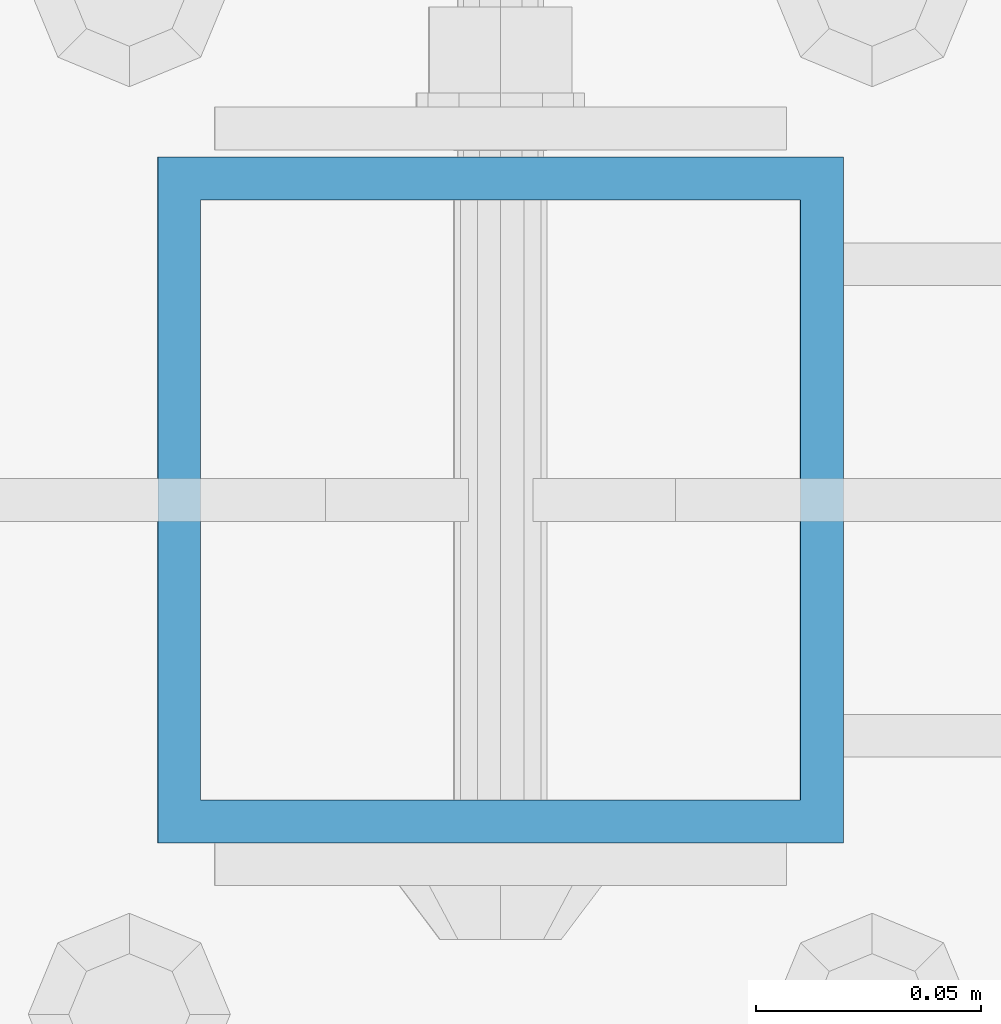
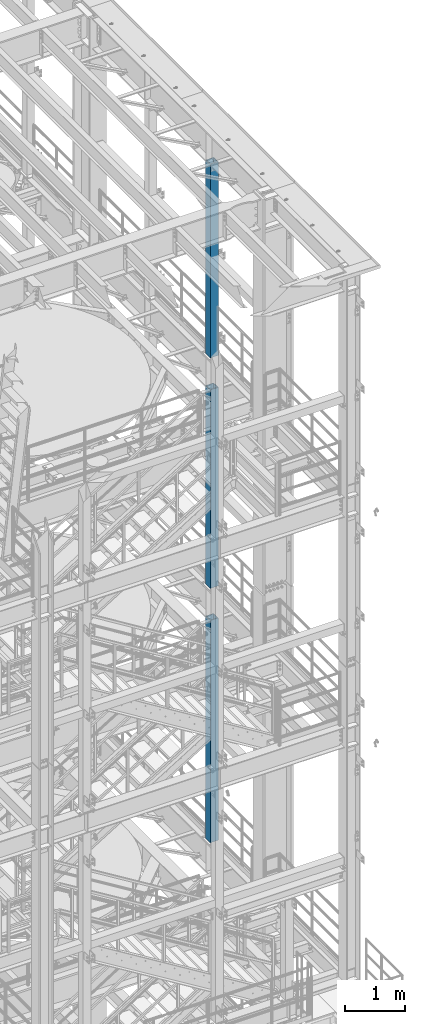
# One storey, part 674 of 1876: 3 columns, 3 elements without a shape of their own.
"""IFC2X3 building model written with IfcOpenShell, lengths in millimetres."""

from ifc_helpers import new_model, si_unit, frame, origin_with_axes, place, context, subcontext, project, spatial, faceted_brep, material, type_object, element, aggregate, save


model = new_model("IFC2X3")

# Units and contexts
model_context = context("Model", 3, precision=1e-05, world=origin_with_axes())
body_context = subcontext(model_context, "Body", "Model", "MODEL_VIEW")
ifc_project = project(units=[si_unit("LENGTHUNIT", "METRE", prefix="MILLI"), si_unit("AREAUNIT", "SQUARE_METRE"), si_unit("VOLUMEUNIT", "CUBIC_METRE"), si_unit("MASSUNIT", "GRAM", prefix="KILO"), si_unit("TIMEUNIT", "SECOND"), si_unit("PLANEANGLEUNIT", "RADIAN"), si_unit("SOLIDANGLEUNIT", "STERADIAN"), si_unit("THERMODYNAMICTEMPERATUREUNIT", "DEGREE_CELSIUS"), si_unit("LUMINOUSINTENSITYUNIT", "LUMEN")], contexts=[model_context])

# Site, building, storey
site_placement = place(None, origin_with_axes())
site = spatial("IfcSite", under=ifc_project, at=site_placement, CompositionType="ELEMENT")
building_placement = place(site_placement, origin_with_axes())
building = spatial("IfcBuilding", under=site, at=building_placement, Name="Undefined", CompositionType="ELEMENT")
storey_placement = place(building_placement, origin_with_axes())
storey = spatial("IfcBuildingStorey", under=building, at=storey_placement, Name="Undefined", CompositionType="ELEMENT", Elevation=0.0)

# Assembly, column
assembly_1_placement = place(storey_placement, origin_with_axes())
assembly_1 = element("IfcElementAssembly", 1, at=assembly_1_placement, inside=storey, Name="BEAM", AssemblyPlace="NOTDEFINED", PredefinedType="RIGID_FRAME")
ifc_material = material()
column_type = type_object("IfcColumnType", Name="HSS6X6X3/8", PredefinedType="NOTDEFINED")
column_1_placement = place(assembly_1_placement, frame((7620.0, -2540.0, 17983.2), z_axis=(-1.0, 0.0, 0.0), x_axis=(0.0, 0.0, 1.0)))
column_1 = element("IfcColumn", 2, at=column_1_placement, type_object=column_type, material=ifc_material, Name="COLUMN", ObjectType="HSS6X6X3/8", context=body_context, shape_type="Brep", body=[
    faceted_brep([(12.7000000000016, 66.6750000000002, -66.6750000000002), (12.7000000000016, -66.6750000000002, -66.6750000000002), (3937.0, -66.6750000000002, -66.675), (3937.0, 66.6750000000002, -66.675), (12.7000000000016, -66.6750000000002, 66.6750000000002), (3937.0, -66.6750000000002, 66.675), (12.7000000000016, 66.6750000000002, 66.6750000000002), (3937.0, 66.6750000000002, 66.675), (12.7000000000016, 76.1999999999998, -76.1999999999998), (12.7000000000016, 76.1999999999998, 76.1999999999998), (3937.0, 76.1999999999998, 76.2), (3937.0, 76.1999999999998, -76.2), (12.7000000000016, -76.1999999999998, 76.1999999999998), (3937.0, -76.1999999999998, 76.2), (12.7000000000016, -76.1999999999998, -76.1999999999998), (3937.0, -76.1999999999998, -76.2)], [[[0, 1, 2, 3]], [[1, 4, 5, 2]], [[4, 6, 7, 5]], [[6, 0, 3, 7]], [[8, 9, 10, 11]], [[9, 12, 13, 10]], [[12, 14, 15, 13]], [[14, 8, 11, 15]], [[13, 15, 11, 10], [5, 7, 3, 2]], [[14, 12, 9, 8], [6, 4, 1, 0]]]),
])
aggregate(assembly_1, [column_1])

assembly_2_placement = place(storey_placement, origin_with_axes())
assembly_2 = element("IfcElementAssembly", 3, at=assembly_2_placement, inside=storey, Name="BEAM", AssemblyPlace="NOTDEFINED", PredefinedType="RIGID_FRAME")
column_2_placement = place(assembly_2_placement, frame((7620.0, -2540.0, 13309.6), z_axis=(-1.0, 0.0, 0.0), x_axis=(0.0, 0.0, 1.0)))
column_2 = element("IfcColumn", 4, at=column_2_placement, type_object=column_type, material=ifc_material, Name="COLUMN", ObjectType="HSS6X6X3/8", context=body_context, shape_type="Brep", body=[
    faceted_brep([(12.7000000000016, 66.6750000000002, -66.6750000000002), (12.7000000000016, -66.6750000000002, -66.6750000000002), (4038.6, -66.6750000000002, -66.675), (4038.6, 66.6750000000002, -66.675), (12.7000000000016, -66.6750000000002, 66.6750000000002), (4038.6, -66.6750000000002, 66.675), (12.7000000000016, 66.6750000000002, 66.6750000000002), (4038.6, 66.6750000000002, 66.675), (12.7000000000016, 76.1999999999998, -76.1999999999998), (12.7000000000016, 76.1999999999998, 76.1999999999998), (4038.6, 76.1999999999998, 76.2), (4038.6, 76.1999999999998, -76.2), (12.7000000000016, -76.1999999999998, 76.1999999999998), (4038.6, -76.1999999999998, 76.2), (12.7000000000016, -76.1999999999998, -76.1999999999998), (4038.6, -76.1999999999998, -76.2)], [[[0, 1, 2, 3]], [[1, 4, 5, 2]], [[4, 6, 7, 5]], [[6, 0, 3, 7]], [[8, 9, 10, 11]], [[9, 12, 13, 10]], [[12, 14, 15, 13]], [[14, 8, 11, 15]], [[13, 15, 11, 10], [5, 7, 3, 2]], [[14, 12, 9, 8], [6, 4, 1, 0]]]),
])
aggregate(assembly_2, [column_2])

assembly_3_placement = place(storey_placement, origin_with_axes())
assembly_3 = element("IfcElementAssembly", 5, at=assembly_3_placement, inside=storey, Name="BEAM", AssemblyPlace="NOTDEFINED", PredefinedType="RIGID_FRAME")
column_3_placement = place(assembly_3_placement, frame((7620.0, -2540.0, 8153.4), z_axis=(-0.999999999563517, 0.0, -2.95459999870218e-05), x_axis=(-2.95459999861759e-05, 0.0, 0.999999999563517)))
column_3 = element("IfcColumn", 6, at=column_3_placement, type_object=column_type, material=ifc_material, Name="COLUMN", ObjectType="HSS6X6X3/8", context=body_context, shape_type="Brep", body=[
    faceted_brep([(12.698030025992, 66.6750000000002, -66.675), (12.698030025992, -66.6750000000002, -66.675), (4521.2007045434, -66.6750000000002, -66.675), (4521.2007045434, 66.6750000000002, -66.675), (12.7019699850925, -66.6750000000002, 66.675), (4521.20070454334, -66.6750000000002, 66.675), (12.7019699850925, 66.6750000000002, 66.675), (4521.20070454334, 66.6750000000002, 66.675), (12.6977486003425, 76.1999999999998, -76.2), (12.7022514107421, 76.1999999999998, 76.2), (4521.20070454334, 76.1999999999998, 76.2), (4521.2007045434, 76.1999999999998, -76.2), (12.7022514107421, -76.1999999999998, 76.2), (4521.20070454334, -76.1999999999998, 76.2), (12.6977486003425, -76.1999999999998, -76.2), (4521.2007045434, -76.1999999999998, -76.2)], [[[0, 1, 2, 3]], [[1, 4, 5, 2]], [[4, 6, 7, 5]], [[6, 0, 3, 7]], [[8, 9, 10, 11]], [[9, 12, 13, 10]], [[12, 14, 15, 13]], [[14, 8, 11, 15]], [[13, 15, 11, 10], [5, 7, 3, 2]], [[14, 12, 9, 8], [6, 4, 1, 0]]]),
])
aggregate(assembly_3, [column_3])

save(model, "model.ifc")
